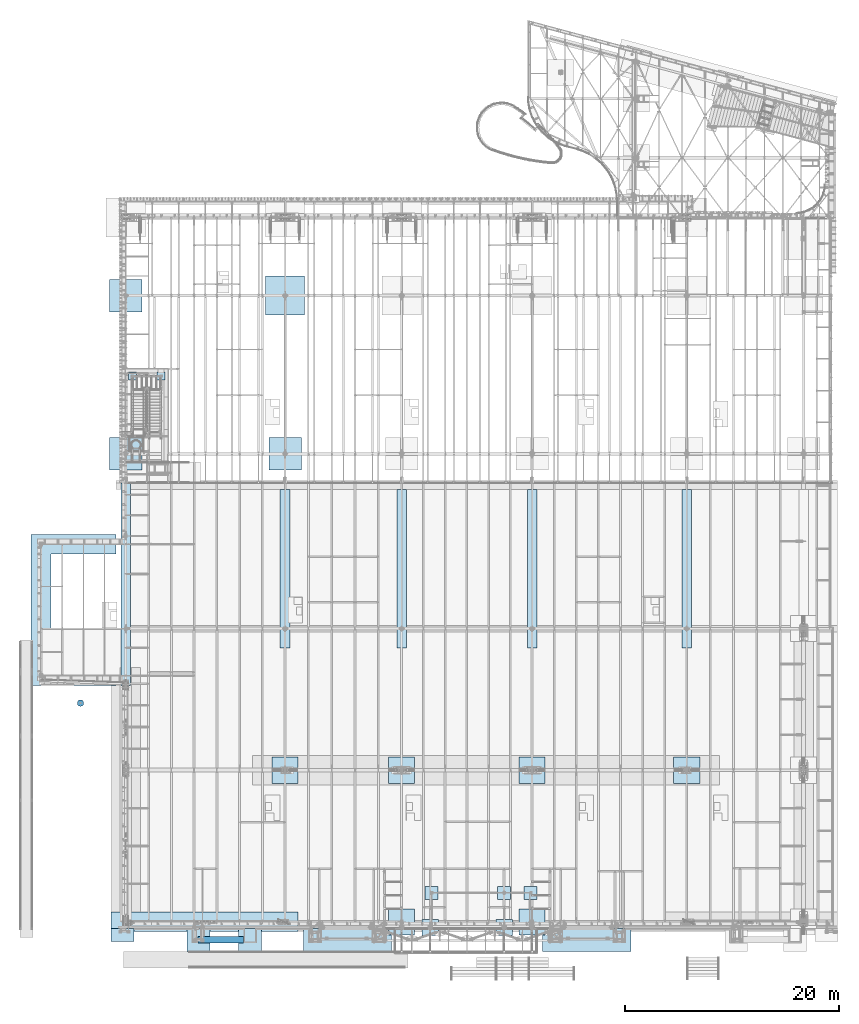
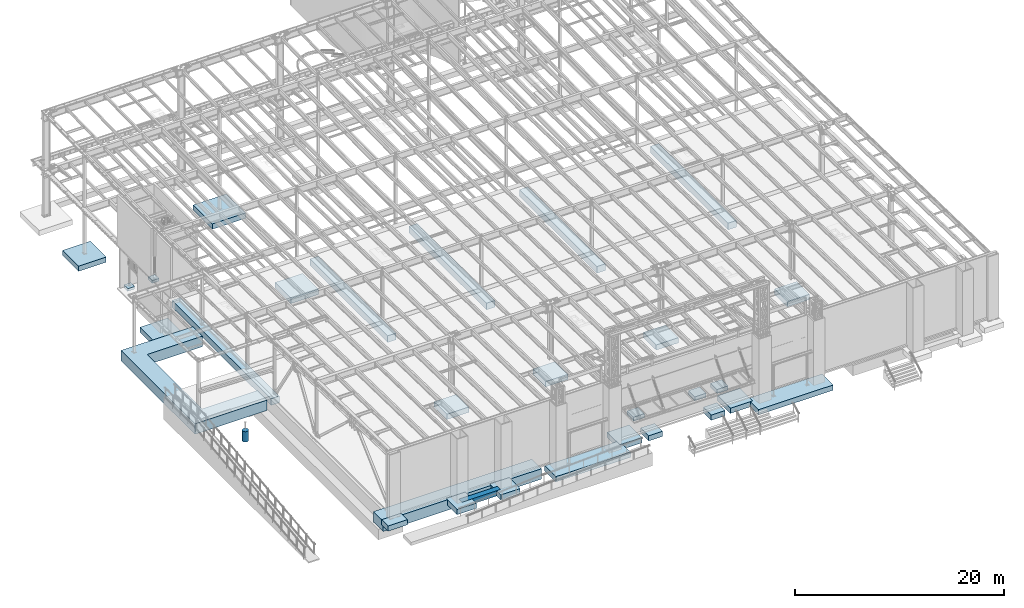
# One storey, part 869 of 1763: 31 footings, 31 elements without a shape of their own.
"""IFC2X3 building model written with IfcOpenShell, lengths in millimetres."""

from ifc_helpers import new_model, si_unit, frame, origin_with_axes, place, context, subcontext, project, spatial, faceted_brep, material, element, aggregate, save


model = new_model("IFC2X3")

# Units and contexts
model_context = context("Model", 3, precision=1e-05, world=origin_with_axes())
body_context = subcontext(model_context, "Body", "Model", "MODEL_VIEW")
ifc_project = project(units=[si_unit("LENGTHUNIT", "METRE", prefix="MILLI"), si_unit("AREAUNIT", "SQUARE_METRE"), si_unit("VOLUMEUNIT", "CUBIC_METRE"), si_unit("MASSUNIT", "GRAM", prefix="KILO"), si_unit("TIMEUNIT", "SECOND"), si_unit("PLANEANGLEUNIT", "RADIAN"), si_unit("SOLIDANGLEUNIT", "STERADIAN"), si_unit("THERMODYNAMICTEMPERATUREUNIT", "DEGREE_CELSIUS"), si_unit("LUMINOUSINTENSITYUNIT", "LUMEN")], contexts=[model_context])

# Site, building, storey
site_placement = place(None, origin_with_axes())
site = spatial("IfcSite", under=ifc_project, at=site_placement, CompositionType="ELEMENT")
building_placement = place(site_placement, origin_with_axes())
building = spatial("IfcBuilding", under=site, at=building_placement, Name="Undefined", CompositionType="ELEMENT")
storey_placement = place(building_placement, origin_with_axes())
storey = spatial("IfcBuildingStorey", under=building, at=storey_placement, Name="Undefined", CompositionType="ELEMENT", Elevation=0.0)

# Assembly, footing
assembly_1_placement = place(storey_placement, origin_with_axes())
assembly_1 = element("IfcElementAssembly", 1, at=assembly_1_placement, inside=storey, Name="PAD FOOTING", AssemblyPlace="NOTDEFINED", PredefinedType="REINFORCEMENT_UNIT")
ifc_material = material(Name="CONCRETE/3000")
footing_1_placement = place(assembly_1_placement, frame((-84073.3721013126, 37299.9, 5.6843418860808e-14), z_axis=(1.0, 0.0, 0.0), x_axis=(0.0, 0.0, 1.0)))
footing_1 = element("IfcFooting", 2, at=footing_1_placement, material=ifc_material, Name="PAD FOOTING", PredefinedType="NOTDEFINED", context=body_context, shape_type="Brep", body=[
    faceted_brep([(0.0, 381.0, -381.0), (0.0, 381.0, 381.0), (304.8, 381.0, 381.0), (304.8, 381.0, -381.0), (0.0, -381.0, 381.0), (304.8, -381.0, 381.0), (0.0, -381.0, -381.0), (304.8, -381.0, -381.0)], [[[0, 1, 2, 3]], [[1, 4, 5, 2]], [[4, 6, 7, 5]], [[6, 0, 3, 7]], [[5, 7, 3, 2]], [[6, 4, 1, 0]]]),
])
aggregate(assembly_1, [footing_1])

assembly_2_placement = place(storey_placement, origin_with_axes())
assembly_2 = element("IfcElementAssembly", 3, at=assembly_2_placement, inside=storey, Name="PAD FOOTING", AssemblyPlace="NOTDEFINED", PredefinedType="REINFORCEMENT_UNIT")
footing_2_placement = place(assembly_2_placement, frame((-86765.8372736874, 37299.9, 5.6843418860808e-14), z_axis=(1.0, 0.0, 0.0), x_axis=(0.0, 0.0, 1.0)))
footing_2 = element("IfcFooting", 4, at=footing_2_placement, material=ifc_material, Name="PAD FOOTING", PredefinedType="NOTDEFINED", context=body_context, shape_type="Brep", body=[
    faceted_brep([(0.0, 381.0, -381.0), (0.0, 381.0, 381.0), (304.8, 381.0, 381.0), (304.8, 381.0, -381.0), (0.0, -381.0, 381.0), (304.8, -381.0, 381.0), (0.0, -381.0, -381.0), (304.8, -381.0, -381.0)], [[[0, 1, 2, 3]], [[1, 4, 5, 2]], [[4, 6, 7, 5]], [[6, 0, 3, 7]], [[5, 7, 3, 2]], [[6, 4, 1, 0]]]),
])
aggregate(assembly_2, [footing_2])

assembly_3_placement = place(storey_placement, origin_with_axes())
assembly_3 = element("IfcElementAssembly", 5, at=assembly_3_placement, inside=storey, Name="PAD FOOTING", AssemblyPlace="NOTDEFINED", PredefinedType="REINFORCEMENT_UNIT")
footing_3_placement = place(assembly_3_placement, frame((-91609.8972391413, 6734.09965622573, 2489.2), z_axis=(1.0, 0.0, 0.0), x_axis=(0.0, 0.0, 1.0)))
footing_3 = element("IfcFooting", 6, at=footing_3_placement, material=ifc_material, Name="PAD FOOTING", PredefinedType="NOTDEFINED", context=body_context, shape_type="Brep", body=[
    faceted_brep([(0.0, -304.8, 0.0), (0.0, -301.047406213398, -47.6812249442592), (1219.2, -301.047406213398, -47.6812249442592), (1219.2, -304.8, 0.0), (0.0, -289.882026166762, -94.1883798854833), (1219.2, -289.882026166762, -94.1883798854833), (0.0, -271.578788572615, -138.376304320613), (1219.2, -271.578788572615, -138.376304320613), (0.0, -246.588379885484, -179.156944898743), (1219.2, -246.588379885484, -179.156944898743), (0.0, -215.52614690566, -215.526146905657), (1219.2, -215.52614690566, -215.526146905657), (0.0, -179.156944898746, -246.588379885477), (1219.2, -179.156944898746, -246.588379885477), (0.0, -138.376304320614, -271.578788572617), (1219.2, -138.376304320614, -271.578788572617), (0.0, -94.1883798854842, -289.882026166757), (1219.2, -94.1883798854842, -289.882026166757), (0.0, -47.6812249442619, -301.047406213402), (1219.2, -47.6812249442619, -301.047406213402), (0.0, 0.0, -304.799987792969), (1219.2, 0.0, -304.800000000003), (0.0, 47.6812249442628, -301.047406213402), (1219.2, 47.6812249442628, -301.047406213402), (0.0, 94.1883798854842, -289.882026166757), (1219.2, 94.1883798854842, -289.882026166757), (0.0, 138.376304320614, -271.578788572617), (1219.2, 138.376304320614, -271.578788572617), (0.0, 179.156944898746, -246.588379885477), (1219.2, 179.156944898746, -246.588379885477), (0.0, 215.52614690566, -215.526146905657), (1219.2, 215.52614690566, -215.526146905657), (0.0, 246.588379885484, -179.156944898743), (1219.2, 246.588379885484, -179.156944898743), (0.0, 271.578788572615, -138.376304320613), (1219.2, 271.578788572615, -138.376304320613), (0.0, 289.882026166762, -94.1883798854833), (1219.2, 289.882026166762, -94.1883798854833), (0.0, 301.047406213398, -47.6812249442592), (1219.2, 301.047406213398, -47.6812249442592), (0.0, 304.8, 0.0), (1219.2, 304.8, 0.0), (0.0, 301.047406213398, 47.6812249442592), (1219.2, 301.047406213398, 47.6812249442592), (0.0, 289.882026166762, 94.1883798854833), (1219.2, 289.882026166762, 94.1883798854833), (0.0, 271.578788572615, 138.376304320613), (1219.2, 271.578788572615, 138.376304320613), (0.0, 246.588379885484, 179.156944898743), (1219.2, 246.588379885484, 179.156944898743), (0.0, 215.52614690566, 215.526146905657), (1219.2, 215.52614690566, 215.526146905657), (0.0, 179.156944898746, 246.588379885477), (1219.2, 179.156944898746, 246.588379885477), (0.0, 138.376304320614, 271.578788572617), (1219.2, 138.376304320614, 271.578788572617), (0.0, 94.1883798854842, 289.882026166757), (1219.2, 94.1883798854842, 289.882026166757), (0.0, 47.6812249442628, 301.047406213402), (1219.2, 47.6812249442628, 301.047406213402), (0.0, 0.0, 304.799987792969), (1219.2, 0.0, 304.800000000003), (0.0, -47.6812249442628, 301.047406213402), (1219.2, -47.6812249442628, 301.047406213402), (0.0, -94.1883798854842, 289.882026166757), (1219.2, -94.1883798854842, 289.882026166757), (0.0, -138.376304320614, 271.578788572617), (1219.2, -138.376304320614, 271.578788572617), (0.0, -179.156944898746, 246.588379885477), (1219.2, -179.156944898746, 246.588379885477), (0.0, -215.52614690566, 215.526146905657), (1219.2, -215.52614690566, 215.526146905657), (0.0, -246.588379885484, 179.156944898743), (1219.2, -246.588379885484, 179.156944898743), (0.0, -271.578788572615, 138.376304320613), (1219.2, -271.578788572615, 138.376304320613), (0.0, -289.882026166762, 94.1883798854833), (1219.2, -289.882026166762, 94.1883798854833), (0.0, -301.047406213398, 47.6812249442592), (1219.2, -301.047406213398, 47.6812249442592)], [[[0, 1, 2, 3]], [[1, 4, 5, 2]], [[4, 6, 7, 5]], [[6, 8, 9, 7]], [[8, 10, 11, 9]], [[10, 12, 13, 11]], [[12, 14, 15, 13]], [[14, 16, 17, 15]], [[16, 18, 19, 17]], [[18, 20, 21, 19]], [[20, 22, 23, 21]], [[22, 24, 25, 23]], [[24, 26, 27, 25]], [[26, 28, 29, 27]], [[28, 30, 31, 29]], [[30, 32, 33, 31]], [[32, 34, 35, 33]], [[34, 36, 37, 35]], [[36, 38, 39, 37]], [[38, 40, 41, 39]], [[40, 42, 43, 41]], [[42, 44, 45, 43]], [[44, 46, 47, 45]], [[46, 48, 49, 47]], [[48, 50, 51, 49]], [[50, 52, 53, 51]], [[52, 54, 55, 53]], [[54, 56, 57, 55]], [[56, 58, 59, 57]], [[58, 60, 61, 59]], [[60, 62, 63, 61]], [[62, 64, 65, 63]], [[64, 66, 67, 65]], [[66, 68, 69, 67]], [[68, 70, 71, 69]], [[70, 72, 73, 71]], [[72, 74, 75, 73]], [[74, 76, 77, 75]], [[76, 78, 79, 77]], [[78, 0, 3, 79]], [[5, 7, 9, 11, 13, 15, 17, 19, 21, 23, 25, 27, 29, 31, 33, 35, 37, 39, 41, 43, 45, 47, 49, 51, 53, 55, 57, 59, 61, 63, 65, 67, 69, 71, 73, 75, 77, 79, 3, 2]], [[78, 76, 74, 72, 70, 68, 66, 64, 62, 60, 58, 56, 54, 52, 50, 48, 46, 44, 42, 40, 38, 36, 34, 32, 30, 28, 26, 24, 22, 20, 18, 16, 14, 12, 10, 8, 6, 4, 1, 0]]]),
])
aggregate(assembly_3, [footing_3])

assembly_4_placement = place(storey_placement, origin_with_axes())
assembly_4 = element("IfcElementAssembly", 7, at=assembly_4_placement, inside=storey, Name="PAD FOOTING", AssemblyPlace="NOTDEFINED", PredefinedType="REINFORCEMENT_UNIT")
footing_4_placement = place(assembly_4_placement, frame((-34949.8372736983, 457.200000000005, 3200.4), z_axis=(1.0, 0.0, 0.0), x_axis=(0.0, 0.0, 1.0)))
footing_4 = element("IfcFooting", 8, at=footing_4_placement, material=ifc_material, Name="PAD FOOTING", PredefinedType="NOTDEFINED", context=body_context, shape_type="Brep", body=[
    faceted_brep([(0.0, 1219.2, -1219.2), (0.0, 1219.2, 1219.2), (609.599999999999, 1219.2, 1219.2), (609.599999999999, 1219.2, -1219.2), (0.0, -1219.2, 1219.2), (609.599999999999, -1219.2, 1219.2), (0.0, -1219.2, -1219.2), (609.599999999999, -1219.2, -1219.2)], [[[0, 1, 2, 3]], [[1, 4, 5, 2]], [[4, 6, 7, 5]], [[6, 0, 3, 7]], [[5, 7, 3, 2]], [[6, 4, 1, 0]]]),
])
aggregate(assembly_4, [footing_4])

assembly_5_placement = place(storey_placement, origin_with_axes())
assembly_5 = element("IfcElementAssembly", 9, at=assembly_5_placement, inside=storey, Name="PAD FOOTING", AssemblyPlace="NOTDEFINED", PredefinedType="REINFORCEMENT_UNIT")
footing_5_placement = place(assembly_5_placement, frame((-72491.0372736983, 457.200000000007, 3200.4), z_axis=(1.0, 0.0, 0.0), x_axis=(0.0, 0.0, 1.0)))
footing_5 = element("IfcFooting", 10, at=footing_5_placement, material=ifc_material, Name="PAD FOOTING", PredefinedType="NOTDEFINED", context=body_context, shape_type="Brep", body=[
    faceted_brep([(0.0, 1219.2, -1219.2), (0.0, 1219.2, 1219.2), (609.599999999999, 1219.2, 1219.2), (609.599999999999, 1219.2, -1219.2), (0.0, -1219.2, 1219.2), (609.599999999999, -1219.2, 1219.2), (0.0, -1219.2, -1219.2), (609.599999999999, -1219.2, -1219.2)], [[[0, 1, 2, 3]], [[1, 4, 5, 2]], [[4, 6, 7, 5]], [[6, 0, 3, 7]], [[5, 7, 3, 2]], [[6, 4, 1, 0]]]),
])
aggregate(assembly_5, [footing_5])

assembly_6_placement = place(storey_placement, origin_with_axes())
assembly_6 = element("IfcElementAssembly", 11, at=assembly_6_placement, inside=storey, Name="STRIP FOOTING", AssemblyPlace="NOTDEFINED", PredefinedType="REINFORCEMENT_UNIT")
footing_6_placement = place(assembly_6_placement, frame((-80644.4371775587, -15367.0000613783, 4724.4), z_axis=(0.0, 0.0, 1.0), x_axis=(1.0, 0.0, 0.0)))
footing_6 = element("IfcFooting", 12, at=footing_6_placement, material=ifc_material, Name="STRIP FOOTING", PredefinedType="NOTDEFINED", context=body_context, shape_type="Brep", body=[
    faceted_brep([(0.0, 304.799999999999, -304.8), (0.0, 304.799999999999, 304.8), (4267.19970703125, 304.799999999999, 304.8), (4267.19970703125, 304.799999999999, -304.8), (0.0, -304.799999999999, 304.8), (4267.19970703125, -304.799999999999, 304.8), (0.0, -304.799999999999, -304.8), (4267.19970703125, -304.799999999999, -304.8)], [[[0, 1, 2, 3]], [[1, 4, 5, 2]], [[4, 6, 7, 5]], [[6, 0, 3, 7]], [[5, 7, 3, 2]], [[6, 4, 1, 0]]]),
])
aggregate(assembly_6, [footing_6])

assembly_7_placement = place(storey_placement, origin_with_axes())
assembly_7 = element("IfcElementAssembly", 13, at=assembly_7_placement, inside=storey, Name="PAD FOOTING", AssemblyPlace="NOTDEFINED", PredefinedType="REINFORCEMENT_UNIT")
footing_7_placement = place(assembly_7_placement, frame((-87680.2372736984, -14960.6000410316, 4419.6), z_axis=(1.0, 0.0, 0.0), x_axis=(0.0, 0.0, 1.0)))
footing_7 = element("IfcFooting", 14, at=footing_7_placement, material=ifc_material, Name="PAD FOOTING", PredefinedType="NOTDEFINED", context=body_context, shape_type="Brep", body=[
    faceted_brep([(0.0, 609.6, -1066.8), (0.0, 609.6, 1066.8), (609.599999999999, 609.6, 1066.8), (609.599999999999, 609.6, -1066.8), (0.0, -609.6, 1066.8), (609.599999999999, -609.6, 1066.8), (0.0, -609.6, -1066.8), (609.599999999999, -609.6, -1066.8)], [[[0, 1, 2, 3]], [[1, 4, 5, 2]], [[4, 6, 7, 5]], [[6, 0, 3, 7]], [[5, 7, 3, 2]], [[6, 4, 1, 0]]]),
])
aggregate(assembly_7, [footing_7])

assembly_8_placement = place(storey_placement, origin_with_axes())
assembly_8 = element("IfcElementAssembly", 15, at=assembly_8_placement, inside=storey, Name="PAD FOOTING", AssemblyPlace="NOTDEFINED", PredefinedType="REINFORCEMENT_UNIT")
footing_8_placement = place(assembly_8_placement, frame((-66649.037225651, -15405.1002383803, 4419.6), z_axis=(1.0, 0.0, 0.0), x_axis=(0.0, 0.0, 1.0)))
footing_8 = element("IfcFooting", 16, at=footing_8_placement, material=ifc_material, Name="PAD FOOTING", PredefinedType="NOTDEFINED", context=body_context, shape_type="Brep", body=[
    faceted_brep([(0.0, 1066.8, -4114.8), (0.0, 1066.8, 4114.8), (609.599999999999, 1066.8, 4114.8), (609.599999999999, 1066.8, -4114.8), (0.0, -1066.8, 4114.8), (609.599999999999, -1066.8, 4114.8), (0.0, -1066.8, -4114.8), (609.599999999999, -1066.8, -4114.8)], [[[0, 1, 2, 3]], [[1, 4, 5, 2]], [[4, 6, 7, 5]], [[6, 0, 3, 7]], [[5, 7, 3, 2]], [[6, 4, 1, 0]]]),
])
aggregate(assembly_8, [footing_8])

assembly_9_placement = place(storey_placement, origin_with_axes())
assembly_9 = element("IfcElementAssembly", 17, at=assembly_9_placement, inside=storey, Name="PAD FOOTING", AssemblyPlace="NOTDEFINED", PredefinedType="REINFORCEMENT_UNIT")
footing_9_placement = place(assembly_9_placement, frame((-80593.6371531446, -15417.7999942397, 4419.60000000001), z_axis=(1.0, 0.0, 0.0), x_axis=(0.0, 0.0, 1.0)))
footing_9 = element("IfcFooting", 18, at=footing_9_placement, material=ifc_material, Name="PAD FOOTING", PredefinedType="NOTDEFINED", context=body_context, shape_type="Brep", body=[
    faceted_brep([(0.0, 1066.8, -1066.8), (0.0, 1066.8, 1066.8), (609.599999999999, 1066.8, 1066.8), (609.599999999999, 1066.8, -1066.8), (0.0, -1066.8, 1066.8), (609.599999999999, -1066.8, 1066.8), (0.0, -1066.8, -1066.8), (609.599999999999, -1066.8, -1066.8)], [[[0, 1, 2, 3]], [[1, 4, 5, 2]], [[4, 6, 7, 5]], [[6, 0, 3, 7]], [[5, 7, 3, 2]], [[6, 4, 1, 0]]]),
])
aggregate(assembly_9, [footing_9])

assembly_10_placement = place(storey_placement, origin_with_axes())
assembly_10 = element("IfcElementAssembly", 19, at=assembly_10_placement, inside=storey, Name="PAD FOOTING", AssemblyPlace="NOTDEFINED", PredefinedType="REINFORCEMENT_UNIT")
footing_10_placement = place(assembly_10_placement, frame((-75767.6372508009, -15417.80011631, 4419.6), z_axis=(1.0, 0.0, 0.0), x_axis=(0.0, 0.0, 1.0)))
footing_10 = element("IfcFooting", 20, at=footing_10_placement, material=ifc_material, Name="PAD FOOTING", PredefinedType="NOTDEFINED", context=body_context, shape_type="Brep", body=[
    faceted_brep([(0.0, 1066.8, -1066.8), (0.0, 1066.8, 1066.8), (609.599999999999, 1066.8, 1066.8), (609.599999999999, 1066.8, -1066.8), (0.0, -1066.8, 1066.8), (609.599999999999, -1066.8, 1066.8), (0.0, -1066.8, -1066.8), (609.599999999999, -1066.8, -1066.8)], [[[0, 1, 2, 3]], [[1, 4, 5, 2]], [[4, 6, 7, 5]], [[6, 0, 3, 7]], [[5, 7, 3, 2]], [[6, 4, 1, 0]]]),
])
aggregate(assembly_10, [footing_10])

assembly_11_placement = place(storey_placement, origin_with_axes())
assembly_11 = element("IfcElementAssembly", 21, at=assembly_11_placement, inside=storey, Name="PAD FOOTING", AssemblyPlace="NOTDEFINED", PredefinedType="REINFORCEMENT_UNIT")
footing_11_placement = place(assembly_11_placement, frame((-44297.0376651041, -15417.8001753089, 4419.6), z_axis=(1.0, 0.0, 0.0), x_axis=(0.0, 0.0, 1.0)))
footing_11 = element("IfcFooting", 22, at=footing_11_placement, material=ifc_material, Name="PAD FOOTING", PredefinedType="NOTDEFINED", context=body_context, shape_type="Brep", body=[
    faceted_brep([(0.0, 1066.8, -4114.8), (0.0, 1066.8, 4114.8), (609.599999999999, 1066.8, 4114.8), (609.599999999999, 1066.8, -4114.8), (0.0, -1066.8, 4114.8), (609.599999999999, -1066.8, 4114.8), (0.0, -1066.8, -4114.8), (609.599999999999, -1066.8, -4114.8)], [[[0, 1, 2, 3]], [[1, 4, 5, 2]], [[4, 6, 7, 5]], [[6, 0, 3, 7]], [[5, 7, 3, 2]], [[6, 4, 1, 0]]]),
])
aggregate(assembly_11, [footing_11])

assembly_12_placement = place(storey_placement, origin_with_axes())
assembly_12 = element("IfcElementAssembly", 23, at=assembly_12_placement, inside=storey, Name="PAD FOOTING", AssemblyPlace="NOTDEFINED", PredefinedType="REINFORCEMENT_UNIT")
footing_12_placement = place(assembly_12_placement, frame((-52018.6372736983, -14249.4002742641, 4419.6), z_axis=(1.0, 0.0, 0.0), x_axis=(0.0, 0.0, 1.0)))
footing_12 = element("IfcFooting", 24, at=footing_12_placement, material=ifc_material, Name="PAD FOOTING", PredefinedType="NOTDEFINED", context=body_context, shape_type="Brep", body=[
    faceted_brep([(0.0, 762.0, -762.0), (0.0, 762.0, 762.0), (609.599999999999, 762.0, 762.0), (609.599999999999, 762.0, -762.0), (0.0, -762.0, 762.0), (609.599999999999, -762.0, 762.0), (0.0, -762.0, -762.0), (609.599999999999, -762.0, -762.0)], [[[0, 1, 2, 3]], [[1, 4, 5, 2]], [[4, 6, 7, 5]], [[6, 0, 3, 7]], [[5, 7, 3, 2]], [[6, 4, 1, 0]]]),
])
aggregate(assembly_12, [footing_12])

assembly_13_placement = place(storey_placement, origin_with_axes())
assembly_13 = element("IfcElementAssembly", 25, at=assembly_13_placement, inside=storey, Name="PAD FOOTING", AssemblyPlace="NOTDEFINED", PredefinedType="REINFORCEMENT_UNIT")
footing_13_placement = place(assembly_13_placement, frame((-58917.9122752341, -14249.400306344, 4419.6), z_axis=(1.0, 0.0, 0.0), x_axis=(0.0, 0.0, 1.0)))
footing_13 = element("IfcFooting", 26, at=footing_13_placement, material=ifc_material, Name="PAD FOOTING", PredefinedType="NOTDEFINED", context=body_context, shape_type="Brep", body=[
    faceted_brep([(0.0, 762.0, -762.0), (0.0, 762.0, 762.0), (609.599999999999, 762.0, 762.0), (609.599999999999, 762.0, -762.0), (0.0, -762.0, 762.0), (609.599999999999, -762.0, 762.0), (0.0, -762.0, -762.0), (609.599999999999, -762.0, -762.0)], [[[0, 1, 2, 3]], [[1, 4, 5, 2]], [[4, 6, 7, 5]], [[6, 0, 3, 7]], [[5, 7, 3, 2]], [[6, 4, 1, 0]]]),
])
aggregate(assembly_13, [footing_13])

assembly_14_placement = place(storey_placement, origin_with_axes())
assembly_14 = element("IfcElementAssembly", 27, at=assembly_14_placement, inside=storey, Name="PAD FOOTING", AssemblyPlace="NOTDEFINED", PredefinedType="REINFORCEMENT_UNIT")
footing_14_placement = place(assembly_14_placement, frame((-49567.5372736984, -10998.1999679201, 4572.0), z_axis=(1.0, 0.0, 0.0), x_axis=(0.0, 0.0, 1.0)))
footing_14 = element("IfcFooting", 28, at=footing_14_placement, material=ifc_material, Name="PAD FOOTING", PredefinedType="NOTDEFINED", context=body_context, shape_type="Brep", body=[
    faceted_brep([(0.0, 609.599999999999, -609.599999999999), (0.0, 609.599999999999, 609.599999999999), (457.2, 609.599999999999, 609.599999999999), (457.2, 609.599999999999, -609.599999999999), (0.0, -609.599999999999, 609.599999999999), (457.2, -609.599999999999, 609.599999999999), (0.0, -609.599999999999, -609.599999999999), (457.2, -609.599999999999, -609.599999999999)], [[[0, 1, 2, 3]], [[1, 4, 5, 2]], [[4, 6, 7, 5]], [[6, 0, 3, 7]], [[5, 7, 3, 2]], [[6, 4, 1, 0]]]),
])
aggregate(assembly_14, [footing_14])

assembly_15_placement = place(storey_placement, origin_with_axes())
assembly_15 = element("IfcElementAssembly", 29, at=assembly_15_placement, inside=storey, Name="PAD FOOTING", AssemblyPlace="NOTDEFINED", PredefinedType="REINFORCEMENT_UNIT")
footing_15_placement = place(assembly_15_placement, frame((-52018.6372736983, -10998.1999679201, 4572.0), z_axis=(1.0, 0.0, 0.0), x_axis=(0.0, 0.0, 1.0)))
footing_15 = element("IfcFooting", 30, at=footing_15_placement, material=ifc_material, Name="PAD FOOTING", PredefinedType="NOTDEFINED", context=body_context, shape_type="Brep", body=[
    faceted_brep([(0.0, 609.599999999999, -609.599999999999), (0.0, 609.599999999999, 609.599999999999), (457.2, 609.599999999999, 609.599999999999), (457.2, 609.599999999999, -609.599999999999), (0.0, -609.599999999999, 609.599999999999), (457.2, -609.599999999999, 609.599999999999), (0.0, -609.599999999999, -609.599999999999), (457.2, -609.599999999999, -609.599999999999)], [[[0, 1, 2, 3]], [[1, 4, 5, 2]], [[4, 6, 7, 5]], [[6, 0, 3, 7]], [[5, 7, 3, 2]], [[6, 4, 1, 0]]]),
])
aggregate(assembly_15, [footing_15])

assembly_16_placement = place(storey_placement, origin_with_axes())
assembly_16 = element("IfcElementAssembly", 31, at=assembly_16_placement, inside=storey, Name="PAD FOOTING", AssemblyPlace="NOTDEFINED", PredefinedType="REINFORCEMENT_UNIT")
footing_16_placement = place(assembly_16_placement, frame((-58787.7372752341, -10998.2, 4572.0), z_axis=(1.0, 0.0, 0.0), x_axis=(0.0, 0.0, 1.0)))
footing_16 = element("IfcFooting", 32, at=footing_16_placement, material=ifc_material, Name="PAD FOOTING", PredefinedType="NOTDEFINED", context=body_context, shape_type="Brep", body=[
    faceted_brep([(0.0, 609.599999999999, -609.599999999999), (0.0, 609.599999999999, 609.599999999999), (457.2, 609.599999999999, 609.599999999999), (457.2, 609.599999999999, -609.599999999999), (0.0, -609.599999999999, 609.599999999999), (457.2, -609.599999999999, 609.599999999999), (0.0, -609.599999999999, -609.599999999999), (457.2, -609.599999999999, -609.599999999999)], [[[0, 1, 2, 3]], [[1, 4, 5, 2]], [[4, 6, 7, 5]], [[6, 0, 3, 7]], [[5, 7, 3, 2]], [[6, 4, 1, 0]]]),
])
aggregate(assembly_16, [footing_16])

assembly_17_placement = place(storey_placement, origin_with_axes())
assembly_17 = element("IfcElementAssembly", 33, at=assembly_17_placement, inside=storey, Name="STRIP FOOTING", AssemblyPlace="NOTDEFINED", PredefinedType="REINFORCEMENT_UNIT")
footing_17_placement = place(assembly_17_placement, frame((-88289.8372736983, 21590.0, 4419.6), z_axis=(0.0, 0.0, 1.0), x_axis=(-1.0, 0.0, 0.0)))
footing_17 = element("IfcFooting", 34, at=footing_17_placement, material=ifc_material, Name="STRIP FOOTING", PredefinedType="NOTDEFINED", context=body_context, shape_type="Brep", body=[
    faceted_brep([(0.0, -914.400000000001, -609.6), (0.0, -914.400000000001, 609.6), (0.0, 914.400000000001, 609.6), (0.0, 914.400000000001, -609.6), (6095.99990234376, 914.400000000001, 609.6), (6095.99990234376, 914.400000000001, -609.6), (7924.79990234374, -914.400000000001, -609.6), (7924.79990234374, -914.400000000001, 609.6), (6095.99990234376, 11379.199609375, 609.6), (6095.99990234376, 11379.199609375, -609.6), (7924.79990234374, 13207.999609375, -609.6), (7924.79990234374, 13207.999609375, 609.6), (2.44140683207661e-05, 11379.199609375, 609.6), (2.44140683207661e-05, 11379.199609375, -609.6), (2.44140683207661e-05, 13207.999609375, 609.6), (2.44140683207661e-05, 13207.999609375, -609.6)], [[[0, 1, 2, 3]], [[3, 2, 4, 5]], [[1, 0, 6, 7]], [[5, 4, 8, 9]], [[7, 6, 10, 11]], [[9, 8, 12, 13]], [[8, 4, 2, 1, 7, 11, 14, 12]], [[11, 10, 15, 14]], [[10, 6, 0, 3, 5, 9, 13, 15]], [[14, 15, 13, 12]]]),
])
aggregate(assembly_17, [footing_17])

assembly_18_placement = place(storey_placement, origin_with_axes())
assembly_18 = element("IfcElementAssembly", 35, at=assembly_18_placement, inside=storey, Name="STRIP FOOTING", AssemblyPlace="NOTDEFINED", PredefinedType="REINFORCEMENT_UNIT")
footing_18_placement = place(assembly_18_placement, frame((-88747.0372736984, -13716.0, 4419.6), z_axis=(0.0, 0.0, 1.0), x_axis=(1.0, 0.0, 0.0)))
footing_18 = element("IfcFooting", 36, at=footing_18_placement, material=ifc_material, Name="STRIP FOOTING", PredefinedType="NOTDEFINED", context=body_context, shape_type="Brep", body=[
    faceted_brep([(0.0, 914.400000000001, -609.6), (0.0, 914.400000000001, 609.6), (17475.2, 914.4, 609.6), (17475.2, 914.4, -609.6), (0.0, -914.400000000001, 609.6), (17475.2, -914.4, 609.6), (0.0, -914.400000000001, -609.6), (17475.2, -914.4, -609.6)], [[[0, 1, 2, 3]], [[1, 4, 5, 2]], [[4, 6, 7, 5]], [[6, 0, 3, 7]], [[5, 7, 3, 2]], [[6, 4, 1, 0]]]),
])
aggregate(assembly_18, [footing_18])

assembly_19_placement = place(storey_placement, origin_with_axes())
assembly_19 = element("IfcElementAssembly", 37, at=assembly_19_placement, inside=storey, Name="STRIP FOOTING", AssemblyPlace="NOTDEFINED", PredefinedType="REINFORCEMENT_UNIT")
footing_19_placement = place(assembly_19_placement, frame((-34949.8372736984, 11861.8, 4641.85), z_axis=(0.0, 0.0, 1.0), x_axis=(0.0, 1.0, 0.0)))
footing_19 = element("IfcFooting", 38, at=footing_19_placement, material=ifc_material, Name="STRIP FOOTING", PredefinedType="NOTDEFINED", context=body_context, shape_type="Brep", body=[
    faceted_brep([(0.0, 457.200000000001, -387.35), (0.0, 457.200000000001, 387.35), (14808.2, 457.199999999997, 387.35), (14808.2, 457.199999999997, -387.35), (0.0, -457.200000000001, 387.35), (14808.2, -457.199999999997, 387.35), (0.0, -457.200000000001, -387.35), (14808.2, -457.199999999997, -387.35)], [[[0, 1, 2, 3]], [[1, 4, 5, 2]], [[4, 6, 7, 5]], [[6, 0, 3, 7]], [[5, 7, 3, 2]], [[6, 4, 1, 0]]]),
])
aggregate(assembly_19, [footing_19])

assembly_20_placement = place(storey_placement, origin_with_axes())
assembly_20 = element("IfcElementAssembly", 39, at=assembly_20_placement, inside=storey, Name="STRIP FOOTING", AssemblyPlace="NOTDEFINED", PredefinedType="REINFORCEMENT_UNIT")
footing_20_placement = place(assembly_20_placement, frame((-49402.4372736983, 11861.8, 4641.85), z_axis=(0.0, 0.0, 1.0), x_axis=(0.0, 1.0, 0.0)))
footing_20 = element("IfcFooting", 40, at=footing_20_placement, material=ifc_material, Name="STRIP FOOTING", PredefinedType="NOTDEFINED", context=body_context, shape_type="Brep", body=[
    faceted_brep([(0.0, 457.200000000001, -387.35), (0.0, 457.200000000001, 387.35), (14808.2, 457.199999999997, 387.35), (14808.2, 457.199999999997, -387.35), (0.0, -457.200000000001, 387.35), (14808.2, -457.199999999997, 387.35), (0.0, -457.200000000001, -387.35), (14808.2, -457.199999999997, -387.35)], [[[0, 1, 2, 3]], [[1, 4, 5, 2]], [[4, 6, 7, 5]], [[6, 0, 3, 7]], [[5, 7, 3, 2]], [[6, 4, 1, 0]]]),
])
aggregate(assembly_20, [footing_20])

assembly_21_placement = place(storey_placement, origin_with_axes())
assembly_21 = element("IfcElementAssembly", 41, at=assembly_21_placement, inside=storey, Name="STRIP FOOTING", AssemblyPlace="NOTDEFINED", PredefinedType="REINFORCEMENT_UNIT")
footing_21_placement = place(assembly_21_placement, frame((-61594.4372736983, 11861.8, 4641.85), z_axis=(0.0, 0.0, 1.0), x_axis=(0.0, 1.0, 0.0)))
footing_21 = element("IfcFooting", 42, at=footing_21_placement, material=ifc_material, Name="STRIP FOOTING", PredefinedType="NOTDEFINED", context=body_context, shape_type="Brep", body=[
    faceted_brep([(0.0, 457.200000000001, -387.35), (0.0, 457.200000000001, 387.35), (14808.2, 457.199999999997, 387.35), (14808.2, 457.199999999997, -387.35), (0.0, -457.200000000001, 387.35), (14808.2, -457.199999999997, 387.35), (0.0, -457.200000000001, -387.35), (14808.2, -457.199999999997, -387.35)], [[[0, 1, 2, 3]], [[1, 4, 5, 2]], [[4, 6, 7, 5]], [[6, 0, 3, 7]], [[5, 7, 3, 2]], [[6, 4, 1, 0]]]),
])
aggregate(assembly_21, [footing_21])

assembly_22_placement = place(storey_placement, origin_with_axes())
assembly_22 = element("IfcElementAssembly", 43, at=assembly_22_placement, inside=storey, Name="STRIP FOOTING", AssemblyPlace="NOTDEFINED", PredefinedType="REINFORCEMENT_UNIT")
footing_22_placement = place(assembly_22_placement, frame((-72491.0372736984, 11861.8, 4641.85), z_axis=(0.0, 0.0, 1.0), x_axis=(0.0, 1.0, 0.0)))
footing_22 = element("IfcFooting", 44, at=footing_22_placement, material=ifc_material, Name="STRIP FOOTING", PredefinedType="NOTDEFINED", context=body_context, shape_type="Brep", body=[
    faceted_brep([(0.0, 457.200000000001, -387.35), (0.0, 457.200000000001, 387.35), (14808.2, 457.199999999997, 387.35), (14808.2, 457.199999999997, -387.35), (0.0, -457.200000000001, 387.35), (14808.2, -457.199999999997, 387.35), (0.0, -457.200000000001, -387.35), (14808.2, -457.199999999997, -387.35)], [[[0, 1, 2, 3]], [[1, 4, 5, 2]], [[4, 6, 7, 5]], [[6, 0, 3, 7]], [[5, 7, 3, 2]], [[6, 4, 1, 0]]]),
])
aggregate(assembly_22, [footing_22])

assembly_23_placement = place(storey_placement, origin_with_axes())
assembly_23 = element("IfcElementAssembly", 45, at=assembly_23_placement, inside=storey, Name="STRIP FOOTING", AssemblyPlace="NOTDEFINED", PredefinedType="REINFORCEMENT_UNIT")
footing_23_placement = place(assembly_23_placement, frame((-87375.4372736983, 8382.000390625, 4641.85), z_axis=(0.0, 0.0, 1.0), x_axis=(0.0, 1.0, 0.0)))
footing_23 = element("IfcFooting", 46, at=footing_23_placement, material=ifc_material, Name="STRIP FOOTING", PredefinedType="NOTDEFINED", context=body_context, shape_type="Brep", body=[
    faceted_brep([(0.0, 457.200000000001, -387.35), (0.0, 457.200000000001, 387.35), (18897.599609375, 457.199999999997, 387.35), (18897.599609375, 457.199999999997, -387.35), (0.0, -457.200000000001, 387.35), (18897.599609375, -457.199999999997, 387.35), (0.0, -457.200000000001, -387.35), (18897.599609375, -457.199999999997, -387.35)], [[[0, 1, 2, 3]], [[1, 4, 5, 2]], [[4, 6, 7, 5]], [[6, 0, 3, 7]], [[5, 7, 3, 2]], [[6, 4, 1, 0]]]),
])
aggregate(assembly_23, [footing_23])

assembly_24_placement = place(storey_placement, origin_with_axes())
assembly_24 = element("IfcElementAssembly", 47, at=assembly_24_placement, inside=storey, Name="PAD FOOTING", AssemblyPlace="NOTDEFINED", PredefinedType="REINFORCEMENT_UNIT")
footing_24_placement = place(assembly_24_placement, frame((-49402.4372736983, -13716.0, 4419.6), z_axis=(1.0, 0.0, 0.0), x_axis=(0.0, 0.0, 1.0)))
footing_24 = element("IfcFooting", 48, at=footing_24_placement, material=ifc_material, Name="PAD FOOTING", PredefinedType="NOTDEFINED", context=body_context, shape_type="Brep", body=[
    faceted_brep([(0.0, 1219.2, -1219.2), (0.0, 1219.2, 1219.2), (609.599999999999, 1219.2, 1219.2), (609.599999999999, 1219.2, -1219.2), (0.0, -1219.2, 1219.2), (609.599999999999, -1219.2, 1219.2), (0.0, -1219.2, -1219.2), (609.599999999999, -1219.2, -1219.2)], [[[0, 1, 2, 3]], [[1, 4, 5, 2]], [[4, 6, 7, 5]], [[6, 0, 3, 7]], [[5, 7, 3, 2]], [[6, 4, 1, 0]]]),
])
aggregate(assembly_24, [footing_24])

assembly_25_placement = place(storey_placement, origin_with_axes())
assembly_25 = element("IfcElementAssembly", 49, at=assembly_25_placement, inside=storey, Name="PAD FOOTING", AssemblyPlace="NOTDEFINED", PredefinedType="REINFORCEMENT_UNIT")
footing_25_placement = place(assembly_25_placement, frame((-61594.4372736983, -13716.0, 4419.6), z_axis=(1.0, 0.0, 0.0), x_axis=(0.0, 0.0, 1.0)))
footing_25 = element("IfcFooting", 50, at=footing_25_placement, material=ifc_material, Name="PAD FOOTING", PredefinedType="NOTDEFINED", context=body_context, shape_type="Brep", body=[
    faceted_brep([(0.0, 1219.2, -1219.2), (0.0, 1219.2, 1219.2), (609.599999999999, 1219.2, 1219.2), (609.599999999999, 1219.2, -1219.2), (0.0, -1219.2, 1219.2), (609.599999999999, -1219.2, 1219.2), (0.0, -1219.2, -1219.2), (609.599999999999, -1219.2, -1219.2)], [[[0, 1, 2, 3]], [[1, 4, 5, 2]], [[4, 6, 7, 5]], [[6, 0, 3, 7]], [[5, 7, 3, 2]], [[6, 4, 1, 0]]]),
])
aggregate(assembly_25, [footing_25])

assembly_26_placement = place(storey_placement, origin_with_axes())
assembly_26 = element("IfcElementAssembly", 51, at=assembly_26_placement, inside=storey, Name="PAD FOOTING", AssemblyPlace="NOTDEFINED", PredefinedType="REINFORCEMENT_UNIT")
footing_26_placement = place(assembly_26_placement, frame((-49402.4372736983, 457.200000000003, 3200.4), z_axis=(1.0, 0.0, 0.0), x_axis=(0.0, 0.0, 1.0)))
footing_26 = element("IfcFooting", 52, at=footing_26_placement, material=ifc_material, Name="PAD FOOTING", PredefinedType="NOTDEFINED", context=body_context, shape_type="Brep", body=[
    faceted_brep([(0.0, 1219.2, -1219.2), (0.0, 1219.2, 1219.2), (609.599999999999, 1219.2, 1219.2), (609.599999999999, 1219.2, -1219.2), (0.0, -1219.2, 1219.2), (609.599999999999, -1219.2, 1219.2), (0.0, -1219.2, -1219.2), (609.599999999999, -1219.2, -1219.2)], [[[0, 1, 2, 3]], [[1, 4, 5, 2]], [[4, 6, 7, 5]], [[6, 0, 3, 7]], [[5, 7, 3, 2]], [[6, 4, 1, 0]]]),
])
aggregate(assembly_26, [footing_26])

assembly_27_placement = place(storey_placement, origin_with_axes())
assembly_27 = element("IfcElementAssembly", 53, at=assembly_27_placement, inside=storey, Name="PAD FOOTING", AssemblyPlace="NOTDEFINED", PredefinedType="REINFORCEMENT_UNIT")
footing_27_placement = place(assembly_27_placement, frame((-61594.4372736983, 457.200000000003, 3200.4), z_axis=(1.0, 0.0, 0.0), x_axis=(0.0, 0.0, 1.0)))
footing_27 = element("IfcFooting", 54, at=footing_27_placement, material=ifc_material, Name="PAD FOOTING", PredefinedType="NOTDEFINED", context=body_context, shape_type="Brep", body=[
    faceted_brep([(0.0, 1219.2, -1219.2), (0.0, 1219.2, 1219.2), (609.599999999999, 1219.2, 1219.2), (609.599999999999, 1219.2, -1219.2), (0.0, -1219.2, 1219.2), (609.599999999999, -1219.2, 1219.2), (0.0, -1219.2, -1219.2), (609.599999999999, -1219.2, -1219.2)], [[[0, 1, 2, 3]], [[1, 4, 5, 2]], [[4, 6, 7, 5]], [[6, 0, 3, 7]], [[5, 7, 3, 2]], [[6, 4, 1, 0]]]),
])
aggregate(assembly_27, [footing_27])

assembly_28_placement = place(storey_placement, origin_with_axes())
assembly_28 = element("IfcElementAssembly", 55, at=assembly_28_placement, inside=storey, Name="PAD FOOTING", AssemblyPlace="NOTDEFINED", PredefinedType="REINFORCEMENT_UNIT")
footing_28_placement = place(assembly_28_placement, frame((-87375.4372736983, 30022.8, -914.4), z_axis=(1.0, 0.0, 0.0), x_axis=(0.0, 0.0, 1.0)))
footing_28 = element("IfcFooting", 56, at=footing_28_placement, material=ifc_material, Name="PAD FOOTING", PredefinedType="NOTDEFINED", context=body_context, shape_type="Brep", body=[
    faceted_brep([(0.0, 1524.0, -1524.0), (0.0, 1524.0, 1524.0), (609.6, 1524.0, 1524.0), (609.6, 1524.0, -1524.0), (0.0, -1524.0, 1524.0), (609.6, -1524.0, 1524.0), (0.0, -1524.0, -1524.0), (609.6, -1524.0, -1524.0)], [[[0, 1, 2, 3]], [[1, 4, 5, 2]], [[4, 6, 7, 5]], [[6, 0, 3, 7]], [[5, 7, 3, 2]], [[6, 4, 1, 0]]]),
])
aggregate(assembly_28, [footing_28])

assembly_29_placement = place(storey_placement, origin_with_axes())
assembly_29 = element("IfcElementAssembly", 57, at=assembly_29_placement, inside=storey, Name="PAD FOOTING", AssemblyPlace="NOTDEFINED", PredefinedType="REINFORCEMENT_UNIT")
footing_29_placement = place(assembly_29_placement, frame((-72491.0372736984, 30022.8, -914.4), z_axis=(1.0, 0.0, 0.0), x_axis=(0.0, 0.0, 1.0)))
footing_29 = element("IfcFooting", 58, at=footing_29_placement, material=ifc_material, Name="PAD FOOTING", PredefinedType="NOTDEFINED", context=body_context, shape_type="Brep", body=[
    faceted_brep([(0.0, 1524.0, -1524.0), (0.0, 1524.0, 1524.0), (609.6, 1524.0, 1524.0), (609.6, 1524.0, -1524.0), (0.0, -1524.0, 1524.0), (609.6, -1524.0, 1524.0), (0.0, -1524.0, -1524.0), (609.6, -1524.0, -1524.0)], [[[0, 1, 2, 3]], [[1, 4, 5, 2]], [[4, 6, 7, 5]], [[6, 0, 3, 7]], [[5, 7, 3, 2]], [[6, 4, 1, 0]]]),
])
aggregate(assembly_29, [footing_29])

assembly_30_placement = place(storey_placement, origin_with_axes())
assembly_30 = element("IfcElementAssembly", 59, at=assembly_30_placement, inside=storey, Name="PAD FOOTING", AssemblyPlace="NOTDEFINED", PredefinedType="REINFORCEMENT_UNIT")
footing_30_placement = place(assembly_30_placement, frame((-72491.0372736984, 44805.6, -914.4), z_axis=(1.0, 0.0, 0.0), x_axis=(0.0, 0.0, 1.0)))
footing_30 = element("IfcFooting", 60, at=footing_30_placement, material=ifc_material, Name="PAD FOOTING", PredefinedType="NOTDEFINED", context=body_context, shape_type="Brep", body=[
    faceted_brep([(0.0, 1828.8, -1828.8), (0.0, 1828.8, 1828.8), (609.6, 1828.8, 1828.8), (609.6, 1828.8, -1828.8), (0.0, -1828.8, 1828.8), (609.6, -1828.8, 1828.8), (0.0, -1828.8, -1828.8), (609.6, -1828.8, -1828.8)], [[[0, 1, 2, 3]], [[1, 4, 5, 2]], [[4, 6, 7, 5]], [[6, 0, 3, 7]], [[5, 7, 3, 2]], [[6, 4, 1, 0]]]),
])
aggregate(assembly_30, [footing_30])

assembly_31_placement = place(storey_placement, origin_with_axes())
assembly_31 = element("IfcElementAssembly", 61, at=assembly_31_placement, inside=storey, Name="PAD FOOTING", AssemblyPlace="NOTDEFINED", PredefinedType="REINFORCEMENT_UNIT")
footing_31_placement = place(assembly_31_placement, frame((-87375.4372736983, 44805.6, -914.4), z_axis=(1.0, 0.0, 0.0), x_axis=(0.0, 0.0, 1.0)))
footing_31 = element("IfcFooting", 62, at=footing_31_placement, material=ifc_material, Name="PAD FOOTING", PredefinedType="NOTDEFINED", context=body_context, shape_type="Brep", body=[
    faceted_brep([(0.0, 1524.0, -1524.0), (0.0, 1524.0, 1524.0), (609.6, 1524.0, 1524.0), (609.6, 1524.0, -1524.0), (0.0, -1524.0, 1524.0), (609.6, -1524.0, 1524.0), (0.0, -1524.0, -1524.0), (609.6, -1524.0, -1524.0)], [[[0, 1, 2, 3]], [[1, 4, 5, 2]], [[4, 6, 7, 5]], [[6, 0, 3, 7]], [[5, 7, 3, 2]], [[6, 4, 1, 0]]]),
])
aggregate(assembly_31, [footing_31])

save(model, "model.ifc")
